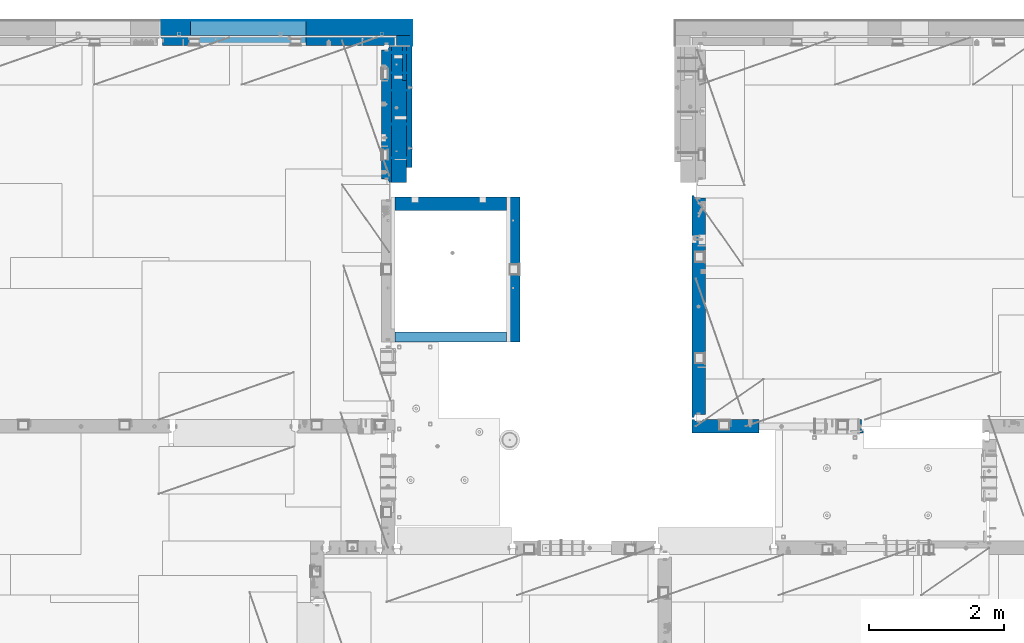
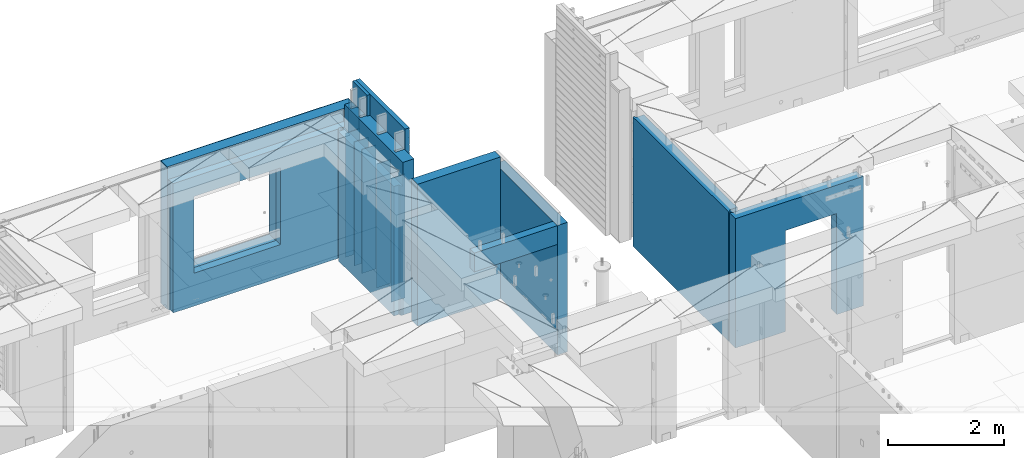
# One storey, part 203 of 309: 19 walls, 5 elements without a shape of their own.
"""IFC2X3 building model written with IfcOpenShell, lengths in millimetres."""

from ifc_helpers import new_model, si_unit, frame, origin_with_axes, place, context, subcontext, project, spatial, faceted_brep, material, type_object, element, aggregate, save


model = new_model("IFC2X3")

# Units and contexts
model_context = context("Model", 3, precision=1e-05, world=origin_with_axes())
body_context = subcontext(model_context, "Body", "Model", "MODEL_VIEW")
ifc_project = project(units=[si_unit("LENGTHUNIT", "METRE", prefix="MILLI"), si_unit("AREAUNIT", "SQUARE_METRE"), si_unit("VOLUMEUNIT", "CUBIC_METRE"), si_unit("MASSUNIT", "GRAM", prefix="KILO"), si_unit("TIMEUNIT", "SECOND"), si_unit("PLANEANGLEUNIT", "RADIAN"), si_unit("SOLIDANGLEUNIT", "STERADIAN"), si_unit("THERMODYNAMICTEMPERATUREUNIT", "DEGREE_CELSIUS"), si_unit("LUMINOUSINTENSITYUNIT", "LUMEN")], contexts=[model_context])

# Site, building, storey
site_placement = place(None, origin_with_axes())
site = spatial("IfcSite", under=ifc_project, at=site_placement, CompositionType="ELEMENT")
building_placement = place(site_placement, origin_with_axes())
building = spatial("IfcBuilding", under=site, at=building_placement, CompositionType="ELEMENT")
storey_placement = place(building_placement, origin_with_axes())
storey = spatial("IfcBuildingStorey", under=building, at=storey_placement, Name="7", CompositionType="ELEMENT", Elevation=0.0)

# Assembly, walls
assembly_1_placement = place(storey_placement, origin_with_axes())
assembly_1 = element("IfcElementAssembly", 1, at=assembly_1_placement, inside=storey, AssemblyPlace="NOTDEFINED", PredefinedType="REINFORCEMENT_UNIT")
ifc_material_1 = material(Name="Undefined")
wall_type_1 = type_object("IfcWallType", PredefinedType="NOTDEFINED")
wall_1_placement = place(assembly_1_placement, frame((17730.0, 22215.0, 101115.0), z_axis=(0.0, 0.0, 1.0), x_axis=(1.0, 0.0, 0.0)))
wall_1 = element("IfcWall", 2, at=wall_1_placement, type_object=wall_type_1, material=ifc_material_1, Name="(PD)", context=body_context, shape_type="Brep", body=[
    faceted_brep([(0.0, 5.0, -1300.0), (0.0, 5.0, 1300.0), (280.0, 5.0, 1300.0), (280.0, 5.0, -1300.0), (0.0, -5.0, 1300.0), (280.0, -5.0, 1300.0), (0.0, -5.0, -1300.0), (280.0, -5.0, -1300.0)], [[[0, 1, 2, 3]], [[1, 4, 5, 2]], [[4, 6, 7, 5]], [[6, 0, 3, 7]], [[5, 7, 3, 2]], [[6, 4, 1, 0]]]),
])
wall_2_placement = place(assembly_1_placement, frame((17730.0, 22515.0, 101115.0), z_axis=(0.0, 0.0, 1.0), x_axis=(1.0, 0.0, 0.0)))
wall_2 = element("IfcWall", 3, at=wall_2_placement, type_object=wall_type_1, material=ifc_material_1, Name="(PD)", context=body_context, shape_type="Brep", body=[
    faceted_brep([(0.0, 5.0, -1300.0), (0.0, 5.0, 1300.0), (280.0, 5.0, 1300.0), (280.0, 5.0, -1300.0), (0.0, -5.0, 1300.0), (280.0, -5.0, 1300.0), (0.0, -5.0, -1300.0), (280.0, -5.0, -1300.0)], [[[0, 1, 2, 3]], [[1, 4, 5, 2]], [[4, 6, 7, 5]], [[6, 0, 3, 7]], [[5, 7, 3, 2]], [[6, 4, 1, 0]]]),
])
wall_3_placement = place(assembly_1_placement, frame((17730.0, 20955.0, 101115.0), z_axis=(0.0, 0.0, 1.0), x_axis=(1.0, 0.0, 0.0)))
wall_3 = element("IfcWall", 4, at=wall_3_placement, type_object=wall_type_1, material=ifc_material_1, Name="(PD)", context=body_context, shape_type="Brep", body=[
    faceted_brep([(0.0, 5.0, -1300.0), (0.0, 5.0, 1300.0), (280.0, 5.0, 1300.0), (280.0, 5.0, -1300.0), (0.0, -5.0, 1300.0), (280.0, -5.0, 1300.0), (0.0, -5.0, -1300.0), (280.0, -5.0, -1300.0)], [[[0, 1, 2, 3]], [[1, 4, 5, 2]], [[4, 6, 7, 5]], [[6, 0, 3, 7]], [[5, 7, 3, 2]], [[6, 4, 1, 0]]]),
])
wall_4_placement = place(assembly_1_placement, frame((17730.0, 21455.0, 101115.0), z_axis=(0.0, 0.0, 1.0), x_axis=(1.0, 0.0, 0.0)))
wall_4 = element("IfcWall", 5, at=wall_4_placement, type_object=wall_type_1, material=ifc_material_1, Name="(PD)", context=body_context, shape_type="Brep", body=[
    faceted_brep([(0.0, 5.0, -1300.0), (0.0, 5.0, 1300.0), (280.0, 5.0, 1300.0), (280.0, 5.0, -1300.0), (0.0, -5.0, 1300.0), (280.0, -5.0, 1300.0), (0.0, -5.0, -1300.0), (280.0, -5.0, -1300.0)], [[[0, 1, 2, 3]], [[1, 4, 5, 2]], [[4, 6, 7, 5]], [[6, 0, 3, 7]], [[5, 7, 3, 2]], [[6, 4, 1, 0]]]),
])
wall_5_placement = place(assembly_1_placement, frame((17730.0, 21955.0, 101115.0), z_axis=(0.0, 0.0, 1.0), x_axis=(1.0, 0.0, 0.0)))
wall_5 = element("IfcWall", 6, at=wall_5_placement, type_object=wall_type_1, material=ifc_material_1, Name="(PD)", context=body_context, shape_type="Brep", body=[
    faceted_brep([(0.0, 5.0, -1300.0), (0.0, 5.0, 1300.0), (280.0, 5.0, 1300.0), (280.0, 5.0, -1300.0), (0.0, -5.0, 1300.0), (280.0, -5.0, 1300.0), (0.0, -5.0, -1300.0), (280.0, -5.0, -1300.0)], [[[0, 1, 2, 3]], [[1, 4, 5, 2]], [[4, 6, 7, 5]], [[6, 0, 3, 7]], [[5, 7, 3, 2]], [[6, 4, 1, 0]]]),
])

# Assembly, wall
assembly_2_placement = place(storey_placement, origin_with_axes())
assembly_2 = element("IfcElementAssembly", 7, at=assembly_2_placement, inside=storey, AssemblyPlace="NOTDEFINED", PredefinedType="REINFORCEMENT_UNIT")
ifc_material_2 = material(Name="CONCRETE/C25/30")
wall_type_2 = type_object("IfcWallType", PredefinedType="NOTDEFINED")
wall_6_placement = place(assembly_2_placement, frame((19559.999681647, 18229.9992663657, 101112.5), z_axis=(0.0, 0.0, 1.0), x_axis=(0.0, 1.0, 0.0)))
wall_6 = element("IfcWall", 8, at=wall_6_placement, type_object=wall_type_2, material=ifc_material_2, context=body_context, shape_type="Brep", body=[
    faceted_brep([(0.0, 100.0, -1357.5), (0.0, 100.0, 1357.5), (2150.00073363433, 100.0, 1357.5), (2150.00073363433, 100.0, -1357.5), (0.0, -100.0, 1357.5), (2150.00073363433, -100.0, 1357.5), (0.0, -100.0, -1357.5), (2150.00073363433, -100.0, -1357.5)], [[[0, 1, 2, 3]], [[1, 4, 5, 2]], [[4, 6, 7, 5]], [[6, 0, 3, 7]], [[5, 7, 3, 2]], [[6, 4, 1, 0]]]),
])

assembly_3_placement = place(storey_placement, origin_with_axes())
assembly_3 = element("IfcElementAssembly", 9, at=assembly_3_placement, inside=storey, AssemblyPlace="NOTDEFINED", PredefinedType="REINFORCEMENT_UNIT")
wall_7_placement = place(assembly_3_placement, frame((22310.0, 16980.0, 101112.5), z_axis=(0.0, 0.0, 1.0), x_axis=(1.0, 0.0, 0.0)))
wall_7 = element("IfcWall", 10, at=wall_7_placement, type_object=wall_type_2, material=ifc_material_2, context=body_context, shape_type="Brep", body=[
    faceted_brep([(890.000686645508, 100.0, 762.5), (890.000686645508, -100.0, 762.5), (890.000686645508, -100.0, -1357.5), (890.000686645508, 100.0, -1357.5), (1910.00068664551, 100.0, 762.5), (1910.00068664551, -100.0, 762.5), (1910.00068664551, 100.0, -1357.5), (1910.00068664551, -100.0, -1357.5), (-100.0, -100.0, -1357.5), (-100.0, -100.0, 1357.5), (-100.0, 100.0, 1357.5), (-100.0, 100.0, -1357.5), (2440.0, -100.0, 1357.5), (2440.0, -100.0, -1357.5), (2440.0, -70.0000000000036, -1357.5), (2440.0, -70.0000000000036, 1357.5), (2410.0, 100.0, 1357.5), (2410.0, -57.0, 1357.5), (2410.0, -57.0, -1357.5), (2410.0, 100.0, -1357.5), (65.0000000000036, 100.0, 1357.5), (52.0, 80.0, 1357.5), (-52.0, 80.0, 1357.5), (-65.0, 100.0, 1357.5), (-65.0, 100.0, -1357.5), (-52.0, 80.0, -1357.5), (52.0, 80.0, -1357.5), (65.0000000000036, 100.0, -1357.5)], [[[0, 1, 2, 3]], [[4, 5, 1, 0]], [[6, 7, 5, 4]], [[8, 9, 10, 11]], [[12, 13, 14, 15]], [[16, 17, 18, 19]], [[15, 14, 18, 17]], [[16, 20, 21, 22, 23, 10, 9, 12, 15, 17]], [[11, 10, 23, 24]], [[22, 25, 24, 23]], [[21, 26, 25, 22]], [[20, 27, 26, 21]], [[8, 11, 24, 25, 26, 27, 3, 2]], [[13, 12, 9, 8, 2, 1, 5, 7]], [[19, 18, 14, 13, 7, 6]], [[3, 27, 20, 16, 19, 6, 4, 0]]]),
])
aggregate(assembly_3, [wall_7])

assembly_4_placement = place(storey_placement, origin_with_axes())
assembly_4 = element("IfcElementAssembly", 11, at=assembly_4_placement, inside=storey, Name="W1", AssemblyPlace="NOTDEFINED", PredefinedType="REINFORCEMENT_UNIT")
wall_8_placement = place(assembly_4_placement, frame((22310.0, 16980.0, 101112.5), z_axis=(0.0, 0.0, 1.0), x_axis=(0.0, 1.0, 0.0)))
wall_8 = element("IfcWall", 12, at=wall_8_placement, type_object=wall_type_2, material=ifc_material_2, context=body_context, shape_type="Brep", body=[
    faceted_brep([(3385.00000172571, 57.0000007519884, 1357.5), (3385.00000172571, 57.0000007519884, -1357.5), (3420.0, 70.0, -1357.5), (3420.0, 70.0, 1357.5), (3384.99999178648, -100.000000948603, 1357.5), (3384.99999178648, -100.0, -1357.5), (130.0, 100.0, -1357.5), (130.0, 100.0, 1357.5), (3420.0, 100.0, 1357.5), (3420.0, 100.0, -1357.5), (130.0, 70.0, -1357.5), (130.0, 70.0, 1357.5), (180.0, 57.0, -1357.5), (180.0, 57.0, 1357.5), (180.0, -100.0, 1357.5), (180.0, -100.0, -1357.5)], [[[0, 1, 2, 3]], [[4, 5, 1, 0]], [[6, 7, 8, 9]], [[7, 6, 10, 11]], [[11, 10, 12, 13]], [[14, 13, 12, 15]], [[3, 8, 7, 11, 13, 14, 4, 0]], [[9, 8, 3, 2]], [[15, 12, 10, 6, 9, 2, 1, 5]], [[14, 15, 5, 4]]]),
])
aggregate(assembly_4, [wall_8])

# Assembly, walls
assembly_5_placement = place(storey_placement, origin_with_axes())
assembly_5 = element("IfcElementAssembly", 13, at=assembly_5_placement, inside=storey, AssemblyPlace="NOTDEFINED", PredefinedType="REINFORCEMENT_UNIT")
ifc_material_3 = material()
wall_type_3 = type_object("IfcWallType", PredefinedType="NOTDEFINED")
wall_9_placement = place(assembly_5_placement, frame((17945.0, 22770.0, 101247.5), z_axis=(0.0, 0.0, 1.0), x_axis=(0.0, -1.0, 0.0)))
wall_9 = element("IfcWall", 14, at=wall_9_placement, type_object=wall_type_3, material=ifc_material_3, context=body_context, shape_type="Brep", body=[
    faceted_brep([(0.0, 110.0, -1492.5), (0.0, 110.0, 1492.5), (150.0, 110.0, 1492.5), (150.0, 110.0, -1492.5), (0.0, -110.0, 1492.5), (150.0, -110.0, 1492.5), (0.0, -110.0, -1492.5), (150.0, -110.0, -1492.5)], [[[0, 1, 2, 3]], [[1, 4, 5, 2]], [[4, 6, 7, 5]], [[6, 0, 3, 7]], [[5, 7, 3, 2]], [[6, 4, 1, 0]]]),
])
wall_10_placement = place(assembly_5_placement, frame((14340.0, 22880.0, 101247.5), z_axis=(0.0, 0.0, 1.0), x_axis=(1.0, 0.0, 0.0)))
wall_10 = element("IfcWall", 15, at=wall_10_placement, type_object=wall_type_3, material=ifc_material_3, context=body_context, shape_type="Brep", body=[
    faceted_brep([(0.0, -110.0, -1492.5), (0.0, 110.0, -1492.5), (3715.0, 110.0, -1492.5), (3715.0, -110.0, -1492.5), (0.0, -110.0, 1492.5), (0.0, 110.0, 1492.5), (3715.0, -110.0, 1492.5), (3715.0, 110.0, 1492.5), (444.999710731721, 110.0, -802.5), (2154.99971073172, 110.0, -802.5), (2154.99971073172, 110.0, 807.5), (444.999710731721, 110.0, 807.5), (444.999710731721, -110.0, -802.5), (444.999710731721, -110.0, 807.5), (2154.99971073172, -110.0, 807.5), (2154.99971073172, -110.0, -802.5)], [[[0, 1, 2, 3]], [[0, 4, 5, 1]], [[5, 4, 6, 7]], [[1, 5, 7, 2], [8, 9, 10, 11]], [[6, 3, 2, 7]], [[4, 0, 3, 6], [12, 13, 14, 15]], [[10, 14, 13, 11]], [[9, 15, 14, 10]], [[8, 12, 15, 9]], [[11, 13, 12, 8]]]),
])

# Wall
wall_type_4 = type_object("IfcWallType", PredefinedType="NOTDEFINED")
wall_11_placement = place(assembly_1_placement, frame((17685.0, 22605.0, 101112.5), z_axis=(0.0, 0.0, 1.0), x_axis=(0.0, -1.0, 0.0)))
wall_11 = element("IfcWall", 16, at=wall_11_placement, type_object=wall_type_4, material=ifc_material_2, context=body_context, shape_type="Brep", body=[
    faceted_brep([(1959.99999772087, -75.0, 1357.5), (1959.99999772087, -75.0, -1357.5), (1959.99999772087, 27.0, -1357.5), (1959.99999772087, 27.0, 1357.5), (2009.99999772087, 40.0, -1357.5), (2009.99999772087, 40.0, 1357.5), (50.0, -75.0, 1357.5), (50.0, 27.0, 1357.5), (50.0, 27.0, -1357.5), (50.0, -75.0, -1357.5), (0.0, 40.0, 1357.5), (0.0, 40.0, -1357.5), (0.0, 75.0, 1357.5), (0.0, 75.0, -1357.5), (2009.99999772087, 75.0, 1357.5), (2009.99999772087, 75.0, -1357.5)], [[[0, 1, 2, 3]], [[3, 2, 4, 5]], [[6, 7, 8, 9]], [[10, 11, 8, 7]], [[12, 13, 11, 10]], [[13, 12, 14, 15]], [[15, 14, 5, 4]], [[11, 13, 15, 4, 2, 1, 9, 8]], [[1, 0, 6, 9]], [[0, 3, 5, 14, 12, 10, 7, 6]]]),
])

wall_12_placement = place(assembly_5_placement, frame((14340.0, 22695.0, 101112.5), z_axis=(0.0, 0.0, 1.0), x_axis=(1.0, 0.0, 0.0)))
wall_12 = element("IfcWall", 17, at=wall_12_placement, type_object=wall_type_4, material=ifc_material_2, context=body_context, shape_type="Brep", body=[
    faceted_brep([(444.999710731721, 75.0, 942.5), (444.999710731721, -75.0, 942.5), (444.999710731721, -75.0, -667.5), (444.999710731721, 75.0, -667.5), (2154.99971073172, -75.0, -667.5), (2154.99971073172, 75.0, -667.5), (2154.99971073172, -75.0, 942.5), (2154.99971073172, 75.0, 942.5), (3305.0, -75.0, 1357.5), (3318.00000041054, -54.9999993903439, 1357.5), (3372.00000031511, -54.9999994175341, 1357.5), (3385.00000278453, -75.0000022791319, 1357.5), (3495.0, -75.0, 1357.5), (3495.0, 75.0, 1357.5), (0.0, 75.0, 1357.5), (0.0, 45.0, 1357.5), (30.0000010550393, 24.9999970131248, 1357.5), (30.0000016637459, -75.0, 1357.5), (3305.0, -75.0, -1357.5), (3318.00000041054, -54.9999993903439, -1357.5), (3372.00000031511, -54.9999994175341, -1357.5), (3385.00000278453, -75.0, -1357.5), (3495.0, -75.0, -1357.5), (3495.0, 75.0, -1357.5), (0.0, 75.0, -1357.5), (0.0, 45.0, -1357.5), (30.0000010550393, 24.9999970131248, -1357.49999999999), (30.0000016637459, -75.0, -1357.5)], [[[0, 1, 2, 3]], [[3, 2, 4, 5]], [[5, 4, 6, 7]], [[7, 6, 1, 0]], [[8, 9, 10, 11, 12, 13, 14, 15, 16, 17]], [[8, 18, 19, 9]], [[9, 19, 20, 10]], [[11, 10, 20, 21]], [[22, 12, 11, 21]], [[12, 22, 23, 13]], [[24, 14, 13, 23], [3, 5, 7, 0]], [[14, 24, 25, 15]], [[15, 25, 26, 16]], [[24, 23, 22, 21, 20, 19, 18, 27, 26, 25]], [[16, 26, 27, 17]], [[18, 8, 17, 27], [2, 1, 6, 4]]]),
])

wall_type_5 = type_object("IfcWallType", PredefinedType="NOTDEFINED")
wall_13_placement = place(assembly_2_placement, frame((17809.9999105288, 20280.0000293051, 101242.5), z_axis=(0.0, 0.0, 1.0), x_axis=(1.0, 0.0, 0.0)))
wall_13 = element("IfcWall", 18, at=wall_13_placement, type_object=wall_type_5, material=ifc_material_2, context=body_context, shape_type="Brep", body=[
    faceted_brep([(0.0, 100.0, -1487.5), (0.0, 100.0, 1487.5), (1649.99977111816, 100.0, 1487.5), (1649.99977111816, 100.0, -1487.5), (0.0, -100.0, 1487.5), (1649.99977111816, -100.0, 1487.5), (0.0, -100.0, -1487.5), (1649.99977111816, -100.0, -1487.5)], [[[0, 1, 2, 3]], [[1, 4, 5, 2]], [[4, 6, 7, 5]], [[6, 0, 3, 7]], [[5, 7, 3, 2]], [[6, 4, 1, 0]]]),
])

wall_type_6 = type_object("IfcWallType", PredefinedType="NOTDEFINED")
wall_14_placement = place(assembly_2_placement, frame((17809.9999105288, 18304.9992663657, 102272.5), z_axis=(0.0, 0.0, 1.0), x_axis=(1.0, 0.0, 0.0)))
wall_14 = element("IfcWall", 19, at=wall_14_placement, type_object=wall_type_6, material=ifc_material_2, context=body_context, shape_type="Brep", body=[
    faceted_brep([(0.0, 75.0, -197.5), (0.0, 75.0, 197.5), (1649.99961853027, 75.0, 197.5), (1649.99961853027, 75.0, -197.5), (0.0, -75.0, 197.5), (1649.99961853027, -75.0, 197.5), (0.0, -75.0, -197.5), (1649.99961853027, -75.0, -197.5)], [[[0, 1, 2, 3]], [[1, 4, 5, 2]], [[4, 6, 7, 5]], [[6, 0, 3, 7]], [[5, 7, 3, 2]], [[6, 4, 1, 0]]]),
])

aggregate(assembly_2, [wall_13, wall_6, wall_14])

ifc_material_4 = material(Name="CONCRETE/C30/37")
wall_type_7 = type_object("IfcWallType", PredefinedType="NOTDEFINED")
wall_15_placement = place(assembly_5_placement, frame((18060.0, 22990.0, 101247.5), z_axis=(0.0, 0.0, 1.0), x_axis=(0.0, -1.0, 0.0)))
wall_15 = element("IfcWall", 20, at=wall_15_placement, type_object=wall_type_7, material=ifc_material_4, context=body_context, shape_type="Brep", body=[
    faceted_brep([(0.0, 5.0, -1492.5), (0.0, 5.0, 1492.5), (370.0, 5.0, 1492.5), (370.0, 5.0, -1492.5), (0.0, -5.0, 1492.5), (370.0, -5.0, 1492.5), (0.0, -5.0, -1492.5), (370.0, -5.0, -1492.5)], [[[0, 1, 2, 3]], [[1, 4, 5, 2]], [[4, 6, 7, 5]], [[6, 0, 3, 7]], [[5, 7, 3, 2]], [[6, 4, 1, 0]]]),
])

wall_16_placement = place(assembly_5_placement, frame((14340.0, 22995.0, 101247.5), z_axis=(0.0, 0.0, 1.0), x_axis=(1.0, 0.0, 0.0)))
wall_16 = element("IfcWall", 21, at=wall_16_placement, type_object=wall_type_7, material=ifc_material_4, context=body_context, shape_type="Brep", body=[
    faceted_brep([(0.0, -5.0, -1492.5), (0.0, 5.0, -1492.5), (3725.0, 5.0, -1492.5), (3725.0, -5.0, -1492.5), (0.0, -5.0, 1492.5), (0.0, 5.0, 1492.5), (3725.0, -5.0, 1492.5), (3725.0, 5.0, 1492.5), (444.999710731721, 5.0, -802.5), (2154.99971073172, 5.0, -802.5), (2154.99971073172, 5.0, 807.5), (444.999710731721, 5.0, 807.5), (444.999710731721, -5.0, -802.5), (444.999710731721, -5.0, 807.5), (2154.99971073172, -5.0, 807.5), (2154.99971073172, -5.0, -802.5)], [[[0, 1, 2, 3]], [[0, 4, 5, 1]], [[5, 4, 6, 7]], [[1, 5, 7, 2], [8, 9, 10, 11]], [[6, 3, 2, 7]], [[4, 0, 3, 6], [12, 13, 14, 15]], [[10, 14, 13, 11]], [[9, 15, 14, 10]], [[8, 12, 15, 9]], [[11, 13, 12, 8]]]),
])

aggregate(assembly_5, [wall_15, wall_9, wall_10, wall_16, wall_12])

wall_type_8 = type_object("IfcWallType", PredefinedType="NOTDEFINED")
wall_17_placement = place(assembly_1_placement, frame((17950.0, 22605.0, 101572.5), z_axis=(0.0, 0.0, 1.0), x_axis=(0.0, -1.0, 0.0)))
wall_17 = element("IfcWall", 22, at=wall_17_placement, type_object=wall_type_8, material=ifc_material_4, context=body_context, shape_type="Brep", body=[
    faceted_brep([(0.0, 30.0, -1817.5), (0.0, 30.0, 1817.5), (500.0, 30.0, 1817.5), (500.0, 30.0, -1817.5), (0.0, -30.0, 1817.5), (500.0, -30.0, 1817.5), (0.0, -30.0, -1817.5), (500.0, -30.0, -1817.5)], [[[0, 1, 2, 3]], [[1, 4, 5, 2]], [[4, 6, 7, 5]], [[6, 0, 3, 7]], [[5, 7, 3, 2]], [[6, 4, 1, 0]]]),
])

ifc_material_5 = material(Name="COS5gt")
wall_type_9 = type_object("IfcWallType", PredefinedType="NOTDEFINED")
wall_18_placement = place(assembly_1_placement, frame((17870.0, 22605.0, 101355.0), z_axis=(0.0, 0.0, 1.0), x_axis=(0.0, -1.0, 0.0)))
wall_18 = element("IfcWall", 23, at=wall_18_placement, type_object=wall_type_9, material=ifc_material_5, context=body_context, shape_type="Brep", body=[
    faceted_brep([(1680.0, -65.0, 1600.0), (1680.0, -65.0, 335.0), (1630.0, -65.0, 335.0), (1630.0, -65.0, 1600.0), (1680.0, 110.0, 1600.0), (1680.0, 110.0, 335.0), (1630.0, 110.0, 335.0), (1630.0, 110.0, 1600.0), (2010.0, 110.0, -1600.0), (2010.0, -110.0, -1600.0), (0.0, -110.0, -1600.0), (0.0, 50.0, -1600.0), (500.0, 50.0, -1600.0), (500.0, 110.0, -1600.0), (2010.0, -110.0, 1600.0), (2010.0, 110.0, 1600.0), (0.0, -110.0, 1600.0), (0.0, 50.0, 1600.0), (125.0, 50.0, 335.0), (125.0, -75.0, 335.0), (175.0, -75.0, 335.0), (175.0, 50.0, 335.0), (125.0, 50.0, 1600.0), (125.0, -75.0, 1600.0), (175.0, -75.0, 1600.0), (175.0, 50.0, 1600.0), (480.0, -75.0, 1600.0), (480.0, -75.0, 335.0), (430.0, -75.0, 335.0), (430.0, -75.0, 1600.0), (480.0, 50.0, 1600.0), (480.0, 50.0, 335.0), (430.0, 50.0, 335.0), (430.0, 50.0, 1600.0), (500.0, 50.0, 1600.0), (500.0, 110.0, 1600.0), (1030.0, 110.0, 335.0), (1030.0, -65.0, 335.0), (1080.0, -65.0, 335.0), (1080.0, 110.0, 335.0), (1030.0, 110.0, 1600.0), (1030.0, -65.0, 1600.0), (1080.0, -65.0, 1600.0), (1080.0, 110.0, 1600.0)], [[[0, 1, 2, 3]], [[4, 5, 1, 0]], [[6, 2, 1, 5]], [[7, 3, 2, 6]], [[8, 9, 10, 11, 12, 13]], [[14, 9, 8, 15]], [[16, 10, 9, 14]], [[10, 16, 17, 11]], [[18, 19, 20, 21]], [[22, 23, 19, 18]], [[24, 20, 19, 23]], [[25, 21, 20, 24]], [[26, 27, 28, 29]], [[30, 31, 27, 26]], [[32, 28, 27, 31]], [[33, 29, 28, 32]], [[31, 30, 34, 12, 11, 17, 22, 18, 21, 25, 33, 32]], [[35, 13, 12, 34]], [[36, 37, 38, 39]], [[40, 41, 37, 36]], [[42, 38, 37, 41]], [[43, 39, 38, 42]], [[5, 4, 15, 8, 13, 35, 40, 36, 39, 43, 7, 6]], [[43, 42, 41, 40, 35, 34, 30, 26, 29, 33, 25, 24, 23, 22, 17, 16, 14, 15, 4, 0, 3, 7]]]),
])

wall_type_10 = type_object("IfcWallType", PredefinedType="NOTDEFINED")
wall_19_placement = place(assembly_1_placement, frame((18022.5, 22620.0, 101572.5), z_axis=(0.0, 0.0, 1.0), x_axis=(0.0, -1.0, 0.0)))
wall_19 = element("IfcWall", 24, at=wall_19_placement, type_object=wall_type_10, material=ifc_material_4, context=body_context, shape_type="Brep", body=[
    faceted_brep([(1720.0, 42.5, 1167.5), (1720.0, -42.5, 1167.5), (1805.0, -42.5, 1167.5), (1805.0, 42.5, 1167.5), (1720.0, 42.5, 1817.5), (1720.0, -42.5, 1817.5), (1720.0, 42.5, 1168.0), (1720.0, 32.5, 1170.0), (1720.0, 32.5, 1180.0), (1720.0, 42.5, 1182.0), (1720.0, 42.5, 1318.0), (1720.0, 32.5, 1320.0), (1720.0, 32.5, 1330.0), (1720.0, 42.5, 1332.0), (1720.0, 42.5, 1468.0), (1720.0, 32.5, 1470.0), (1720.0, 32.5, 1480.0), (1720.0, 42.5, 1482.0), (1720.0, 42.5, 1618.0), (1720.0, 32.5, 1620.0), (1720.0, 32.5, 1630.0), (1720.0, 42.5, 1632.0), (1720.0, 42.5, 1768.0), (1720.0, 32.5, 1770.0), (1720.0, 32.5, 1780.0), (1720.0, 42.5, 1782.0), (15.0, 32.5, 1030.0), (1750.0, 32.5, 1030.0), (1750.0, 32.5, 1020.0), (15.0, 32.5, 1020.0), (15.0, 42.5, 1032.0), (1750.0, 42.5, 1032.0), (1750.0, 42.5, 1018.0), (15.0, 42.5, 1018.0), (15.0, 32.5, 880.0), (1750.0, 32.5, 880.0), (1750.0, 32.5, 870.0), (15.0, 32.5, 870.0), (15.0, 42.5, 882.0), (1750.0, 42.5, 882.0), (1750.0, 42.5, 868.0), (15.0, 42.5, 868.0), (15.0, 32.5, 730.0), (1750.0, 32.5, 730.0), (1750.0, 32.5, 720.0), (15.0, 32.5, 720.0), (15.0, 42.5, 732.0), (1750.0, 42.5, 732.0), (1750.0, 42.5, 718.0), (15.0, 42.5, 718.0), (15.0, 32.5, 580.0), (1750.0, 32.5, 580.0), (1750.0, 32.5, 570.0), (15.0, 32.5, 570.0), (15.0, 42.5, 582.0), (1750.0, 42.5, 582.0), (1750.0, 42.5, 568.0), (15.0, 42.5, 568.0), (15.0, 32.5, 430.0), (1750.0, 32.5, 430.0), (1750.0, 32.5, 420.0), (15.0, 32.5, 420.0), (15.0, 42.5, 432.0), (1750.0, 42.5, 432.0), (1750.0, 42.5, 418.0), (15.0, 42.5, 418.0), (15.0, 32.5, 280.0), (1750.0, 32.5, 280.0), (1750.0, 32.5, 270.0), (15.0, 32.5, 270.0), (15.0, 42.5, 282.0), (1750.0, 42.5, 282.0), (1750.0, 42.5, 268.0), (15.0, 42.5, 268.0), (15.0, 32.5, 130.0), (1750.0, 32.5, 130.0), (1750.0, 32.5, 120.0), (15.0, 32.5, 120.0), (15.0, 42.5, 132.0), (1750.0, 42.5, 132.0), (1750.0, 42.5, 118.0), (15.0, 42.5, 118.0), (15.0, 32.5, -20.0), (1750.0, 32.5, -20.0), (1750.0, 32.5, -30.0), (15.0, 32.5, -30.0), (15.0, 42.5, -18.0), (1750.0, 42.5, -18.0), (1750.0, 42.5, -32.0), (15.0, 42.5, -32.0), (15.0, 32.5, -170.0), (1750.0, 32.5, -170.0), (1750.0, 32.5, -180.0), (15.0, 32.5, -180.0), (15.0, 42.5, -168.0), (1750.0, 42.5, -168.0), (1750.0, 42.5, -182.0), (15.0, 42.5, -182.0), (15.0, 32.5, -320.0), (1750.0, 32.5, -320.0), (1750.0, 32.5, -330.0), (15.0, 32.5, -330.0), (15.0, 42.5, -318.0), (1750.0, 42.5, -318.0), (1750.0, 42.5, -332.0), (15.0, 42.5, -332.0), (15.0, 32.5, -470.0), (1750.0, 32.5, -470.0), (1750.0, 32.5, -480.0), (15.0, 32.5, -480.0), (15.0, 42.5, -468.0), (1750.0, 42.5, -468.0), (1750.0, 42.5, -482.0), (15.0, 42.5, -482.0), (15.0, 32.5, -620.0), (1750.0, 32.5, -620.0), (1750.0, 32.5, -630.0), (15.0, 32.5, -630.0), (15.0, 42.5, -618.0), (1750.0, 42.5, -618.0), (1750.0, 42.5, -632.0), (15.0, 42.5, -632.0), (15.0, 32.5, -770.0), (1750.0, 32.5, -770.0), (1750.0, 32.5, -780.0), (15.0, 32.5, -780.0), (15.0, 42.5, -768.0), (1750.0, 42.5, -768.0), (1750.0, 42.5, -782.0), (15.0, 42.5, -782.0), (15.0, 32.5, -920.0), (1750.0, 32.5, -920.0), (1750.0, 32.5, -930.0), (15.0, 32.5, -930.0), (15.0, 42.5, -918.0), (1750.0, 42.5, -918.0), (1750.0, 42.5, -932.0), (15.0, 42.5, -932.0), (15.0, 32.5, -1070.0), (1750.0, 32.5, -1070.0), (1750.0, 32.5, -1080.0), (15.0, 32.5, -1080.0), (15.0, 42.5, -1068.0), (1750.0, 42.5, -1068.0), (1750.0, 42.5, -1082.0), (15.0, 42.5, -1082.0), (15.0, 32.5, -1220.0), (1750.0, 32.5, -1220.0), (1750.0, 32.5, -1230.0), (15.0, 32.5, -1230.0), (15.0, 42.5, -1218.0), (1750.0, 42.5, -1218.0), (1750.0, 42.5, -1232.0), (15.0, 42.5, -1232.0), (15.0, 32.5, -1370.0), (1750.0, 32.5, -1370.0), (1750.0, 32.5, -1380.0), (15.0, 32.5, -1380.0), (15.0, 42.5, -1368.0), (1750.0, 42.5, -1368.0), (1750.0, 42.5, -1382.0), (15.0, 42.5, -1382.0), (15.0, 32.5, -1520.0), (1750.0, 32.5, -1520.0), (1750.0, 32.5, -1530.0), (15.0, 32.5, -1530.0), (15.0, 42.5, -1518.0), (1750.0, 42.5, -1518.0), (1750.0, 42.5, -1532.0), (15.0, 42.5, -1532.0), (15.0, 32.5, -1670.0), (1750.0, 32.5, -1670.0), (1750.0, 32.5, -1680.0), (15.0, 32.5, -1680.0), (15.0, 42.5, -1668.0), (1750.0, 42.5, -1668.0), (1750.0, 42.5, -1682.0), (15.0, 42.5, -1682.0), (15.0, -42.5, -1817.5), (15.0, 42.5, -1817.5), (1805.0, 42.5, -1817.5), (1805.0, -42.5, -1817.5), (15.0, 32.5, 1770.0), (15.0, 42.5, 1768.0), (15.0, 42.5, 1632.0), (15.0, 32.5, 1630.0), (15.0, 32.5, 1620.0), (15.0, 42.5, 1618.0), (15.0, 42.5, 1482.0), (15.0, 32.5, 1480.0), (15.0, 32.5, 1470.0), (15.0, 42.5, 1468.0), (15.0, 42.5, 1332.0), (15.0, 32.5, 1330.0), (15.0, 32.5, 1320.0), (15.0, 42.5, 1318.0), (15.0, 42.5, 1182.0), (15.0, 32.5, 1180.0), (15.0, 32.5, 1170.0), (15.0, 42.5, 1168.0), (15.0, -42.5, 1817.5), (15.0, 42.5, 1817.5), (15.0, 42.5, 1782.0), (15.0, 32.5, 1780.0)], [[[0, 1, 2, 3]], [[4, 5, 1, 0, 6, 7, 8, 9, 10, 11, 12, 13, 14, 15, 16, 17, 18, 19, 20, 21, 22, 23, 24, 25]], [[26, 27, 28, 29]], [[30, 31, 27, 26]], [[32, 28, 27, 31]], [[33, 29, 28, 32]], [[34, 35, 36, 37]], [[38, 39, 35, 34]], [[40, 36, 35, 39]], [[41, 37, 36, 40]], [[42, 43, 44, 45]], [[46, 47, 43, 42]], [[48, 44, 43, 47]], [[49, 45, 44, 48]], [[50, 51, 52, 53]], [[54, 55, 51, 50]], [[56, 52, 51, 55]], [[57, 53, 52, 56]], [[58, 59, 60, 61]], [[62, 63, 59, 58]], [[64, 60, 59, 63]], [[65, 61, 60, 64]], [[66, 67, 68, 69]], [[70, 71, 67, 66]], [[72, 68, 67, 71]], [[73, 69, 68, 72]], [[74, 75, 76, 77]], [[78, 79, 75, 74]], [[80, 76, 75, 79]], [[81, 77, 76, 80]], [[82, 83, 84, 85]], [[86, 87, 83, 82]], [[88, 84, 83, 87]], [[89, 85, 84, 88]], [[90, 91, 92, 93]], [[94, 95, 91, 90]], [[96, 92, 91, 95]], [[97, 93, 92, 96]], [[98, 99, 100, 101]], [[102, 103, 99, 98]], [[104, 100, 99, 103]], [[105, 101, 100, 104]], [[106, 107, 108, 109]], [[110, 111, 107, 106]], [[112, 108, 107, 111]], [[113, 109, 108, 112]], [[114, 115, 116, 117]], [[118, 119, 115, 114]], [[120, 116, 115, 119]], [[121, 117, 116, 120]], [[122, 123, 124, 125]], [[126, 127, 123, 122]], [[128, 124, 123, 127]], [[129, 125, 124, 128]], [[130, 131, 132, 133]], [[134, 135, 131, 130]], [[136, 132, 131, 135]], [[137, 133, 132, 136]], [[138, 139, 140, 141]], [[142, 143, 139, 138]], [[144, 140, 139, 143]], [[145, 141, 140, 144]], [[146, 147, 148, 149]], [[150, 151, 147, 146]], [[152, 148, 147, 151]], [[153, 149, 148, 152]], [[154, 155, 156, 157]], [[158, 159, 155, 154]], [[160, 156, 155, 159]], [[161, 157, 156, 160]], [[162, 163, 164, 165]], [[166, 167, 163, 162]], [[168, 164, 163, 167]], [[169, 165, 164, 168]], [[170, 171, 172, 173]], [[174, 175, 171, 170]], [[176, 172, 171, 175]], [[177, 173, 172, 176]], [[178, 179, 180, 181]], [[182, 183, 184, 185, 186, 187, 188, 189, 190, 191, 192, 193, 194, 195, 196, 197, 198, 199, 30, 26, 29, 33, 38, 34, 37, 41, 46, 42, 45, 49, 54, 50, 53, 57, 62, 58, 61, 65, 70, 66, 69, 73, 78, 74, 77, 81, 86, 82, 85, 89, 94, 90, 93, 97, 102, 98, 101, 105, 110, 106, 109, 113, 118, 114, 117, 121, 126, 122, 125, 129, 134, 130, 133, 137, 142, 138, 141, 145, 150, 146, 149, 153, 158, 154, 157, 161, 166, 162, 165, 169, 174, 170, 173, 177, 179, 178, 200, 201, 202, 203]], [[202, 201, 4, 25]], [[203, 202, 25, 24]], [[182, 203, 24, 23]], [[183, 182, 23, 22]], [[184, 183, 22, 21]], [[185, 184, 21, 20]], [[186, 185, 20, 19]], [[187, 186, 19, 18]], [[188, 187, 18, 17]], [[189, 188, 17, 16]], [[190, 189, 16, 15]], [[191, 190, 15, 14]], [[192, 191, 14, 13]], [[193, 192, 13, 12]], [[194, 193, 12, 11]], [[195, 194, 11, 10]], [[196, 195, 10, 9]], [[197, 196, 9, 8]], [[198, 197, 8, 7]], [[199, 198, 7, 6]], [[3, 180, 179, 177, 176, 175, 174, 169, 168, 167, 166, 161, 160, 159, 158, 153, 152, 151, 150, 145, 144, 143, 142, 137, 136, 135, 134, 129, 128, 127, 126, 121, 120, 119, 118, 113, 112, 111, 110, 105, 104, 103, 102, 97, 96, 95, 94, 89, 88, 87, 86, 81, 80, 79, 78, 73, 72, 71, 70, 65, 64, 63, 62, 57, 56, 55, 54, 49, 48, 47, 46, 41, 40, 39, 38, 33, 32, 31, 30, 199, 6, 0]], [[181, 180, 3, 2]], [[200, 178, 181, 2, 1, 5]], [[201, 200, 5, 4]]]),
])

aggregate(assembly_1, [wall_1, wall_2, wall_3, wall_4, wall_5, wall_17, wall_18, wall_19, wall_11])

save(model, "model.ifc")
